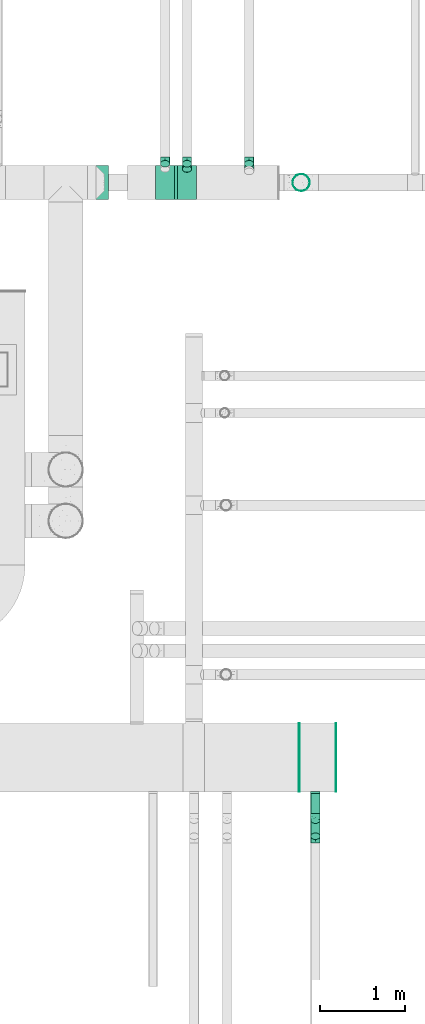
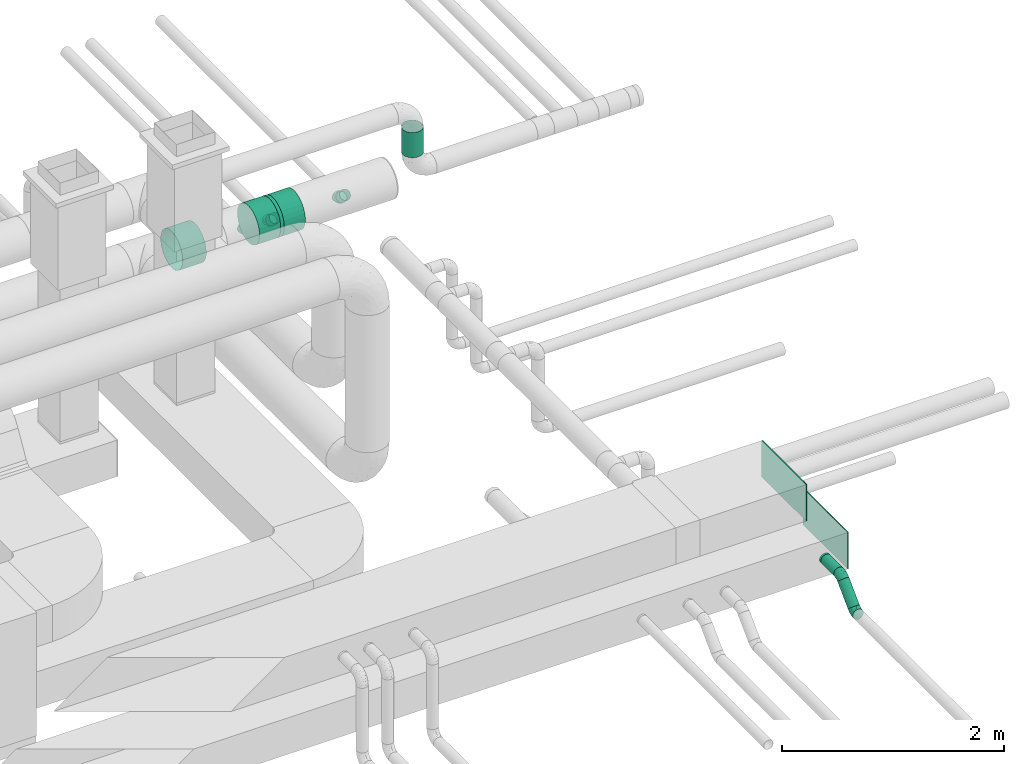
# One storey, part 84 of 91: 10 flow fittings, 7 flow segments.
"""IFC2X3 building model written with IfcOpenShell, lengths in millimetres."""

import ifcopenshell
import ifcopenshell.guid

model = None  # the IFC model being written
_history = None  # IfcOwnerHistory: only IFC2X3 demands one
_inside = {}  # id of a spatial element -> (the spatial element, [elements in it])
_under = {}  # id of a project, library or spatial element -> (it, [spatial elements below it])
_declared = {}  # id of a project -> (the project, [libraries it declares])
_typed = {}  # id of a type object -> (the type object, [elements of that type])
_made_of = {}  # id of a material, layer set ... -> (it, [elements and type objects made of it])


def new_model(schema):
    """Start an empty IFC model of exactly this schema.

    Asked for "IFC4X3", IfcOpenShell would pick the latest addendum, in which some entities
    have other attributes; the version numbers below select the first issue.
    IFC2X3 requires an IfcOwnerHistory on every rooted entity: one is made here for all.
    """
    global model, _history
    if schema == "IFC4X3":
        model = ifcopenshell.file(schema_version=(4, 3, 0, 0))
    else:
        model = ifcopenshell.file(schema=schema)
    _inside.clear()
    _under.clear()
    _declared.clear()
    _typed.clear()
    _made_of.clear()
    _history = None
    if model.schema == "IFC2X3":
        org = make("IfcOrganization", Name="unknown")
        user = make(
            "IfcPersonAndOrganization",
            ThePerson=make("IfcPerson", FamilyName="unknown"),
            TheOrganization=org,
        )
        app = make(
            "IfcApplication",
            ApplicationDeveloper=org,
            Version="unknown",
            ApplicationFullName="unknown",
            ApplicationIdentifier="unknown",
        )
        _history = make(
            "IfcOwnerHistory",
            OwningUser=user,
            OwningApplication=app,
            ChangeAction="ADDED",
            CreationDate=0,
        )
    return model


def make(cls, **values):
    """One entity of the class cls with the attributes given. An attribute that is None is left unset."""
    return model.create_entity(
        cls, **{name: value for name, value in values.items() if value is not None}
    )


def entity(cls, *values):
    """Any entity or typed value of the class cls, its attributes in the order of the schema. None: left unset."""
    e = model.create_entity(cls)
    for i, value in enumerate(values):
        if value is not None:
            e[i] = value
    return e


def rooted(cls, **values):
    """An entity with a GlobalId (a new one), such as an element, a storey or a relation."""
    return make(cls, GlobalId=ifcopenshell.guid.new(), OwnerHistory=_history, **values)


def si_unit(unit_type, name, prefix=None):
    """IfcSIUnit, for example si_unit("LENGTHUNIT", "METRE", prefix="MILLI")."""
    return make("IfcSIUnit", UnitType=unit_type, Prefix=prefix, Name=name)


def converted_unit(unit_type, name, factor, base, dimensions=None, offset=None):
    """IfcConversionBasedUnit, such as the inch: factor (a typed value) times the base unit."""
    return make(
        "IfcConversionBasedUnit"
        if offset is None
        else "IfcConversionBasedUnitWithOffset",
        ConversionOffset=offset,
        Dimensions=None
        if dimensions is None
        else entity("IfcDimensionalExponents", *dimensions),
        UnitType=unit_type,
        Name=name,
        ConversionFactor=make(
            "IfcMeasureWithUnit", ValueComponent=factor, UnitComponent=base
        ),
    )


def derived_unit(unit_type, elements):
    """IfcDerivedUnit: a product of units, each with its exponent."""
    return make(
        "IfcDerivedUnit",
        Elements=[
            make("IfcDerivedUnitElement", Unit=unit, Exponent=power)
            for unit, power in elements
        ],
        UnitType=unit_type,
    )


def assignment(units):
    """IfcUnitAssignment: the units of a project."""
    return None if units is None else make("IfcUnitAssignment", Units=units)


def point(xyz):
    """IfcCartesianPoint."""
    return None if xyz is None else make("IfcCartesianPoint", Coordinates=xyz)


def direction(xyz):
    """IfcDirection."""
    return None if xyz is None else make("IfcDirection", DirectionRatios=xyz)


def frame(location, z_axis=None, x_axis=None):
    """IfcAxis2Placement3D, a coordinate frame: its origin and axes. An axis left out is left unset."""
    return make(
        "IfcAxis2Placement3D",
        Location=point(location),
        Axis=direction(z_axis),
        RefDirection=direction(x_axis),
    )


def frame_2d(location, x_axis=None):
    """IfcAxis2Placement2D, a coordinate frame in the plane: its origin and x axis."""
    return make(
        "IfcAxis2Placement2D", Location=point(location), RefDirection=direction(x_axis)
    )


def origin_with_axes():
    """The frame at (0, 0, 0) with the z axis (0, 0, 1) and the x axis (1, 0, 0) written out."""
    return frame((0.0, 0.0, 0.0), z_axis=(0.0, 0.0, 1.0), x_axis=(1.0, 0.0, 0.0))


def origin_2d_with_axis():
    """The frame at (0, 0) in the plane with the x axis (1, 0) written out."""
    return frame_2d((0.0, 0.0), x_axis=(1.0, 0.0))


def place(relative_to, where):
    """IfcLocalPlacement: puts the frame where relative to a parent placement (None: the world)."""
    return make(
        "IfcLocalPlacement", PlacementRelTo=relative_to, RelativePlacement=where
    )


def context(
    kind, dimensions, precision=None, world=None, true_north=None, identifier=None
):
    """IfcGeometricRepresentationContext, for example the 3D "Model" context."""
    return make(
        "IfcGeometricRepresentationContext",
        ContextIdentifier=identifier,
        ContextType=kind,
        CoordinateSpaceDimension=dimensions,
        Precision=precision,
        WorldCoordinateSystem=world,
        TrueNorth=true_north,
    )


def subcontext(parent, identifier, kind, view, scale=None):
    """IfcGeometricRepresentationSubContext, for example "Body" below "Model"."""
    return make(
        "IfcGeometricRepresentationSubContext",
        ContextIdentifier=identifier,
        ContextType=kind,
        ParentContext=parent,
        TargetScale=scale,
        TargetView=view,
    )


def project(units=None, contexts=None):
    """IfcProject with its units and contexts."""
    return rooted(
        "IfcProject",
        Name="project",
        RepresentationContexts=contexts,
        UnitsInContext=assignment(units),
    )


def spatial(cls, under=None, at=None, **own):
    """A site, building, storey or space (cls), placed at a placement, below another one or the project."""
    s = rooted(cls, ObjectPlacement=at, **own)
    if under is not None:
        _under.setdefault(under.id(), (under, []))[1].append(s)
    return s


def profile(cls, at=None, kind="AREA", **sizes):
    """A parametric profile (cls). Its sizes go by their IFC names, for example OverallWidth=200.0."""
    return make(cls, ProfileType=kind, Position=at, **sizes)


def hollow_circle(**sizes):
    """IfcCircleHollowProfileDef."""
    return profile("IfcCircleHollowProfileDef", **sizes)


def extrude(swept, where, along, depth):
    """IfcExtrudedAreaSolid: the profile swept, set in the frame where, extruded along a direction by depth."""
    return make(
        "IfcExtrudedAreaSolid",
        SweptArea=swept,
        Position=where,
        ExtrudedDirection=direction(along),
        Depth=depth,
    )


def faces_of(points, faces, orient=None, outer=None):
    """IfcFace entities. A face is a list of loops; a loop is a list of indices into points, from 0.

    orient and outer hold one flag for each loop. By default every Orientation is true, the
    first loop of a face is its IfcFaceOuterBound and the others are IfcFaceBound.
    """
    made = []
    for i, loops in enumerate(faces):
        bounds = []
        for j, loop in enumerate(loops):
            is_outer = j == 0 if outer is None else outer[i][j]
            bounds.append(
                make(
                    "IfcFaceOuterBound" if is_outer else "IfcFaceBound",
                    Bound=make("IfcPolyLoop", Polygon=[points[k] for k in loop]),
                    Orientation=True if orient is None else orient[i][j],
                )
            )
        made.append(make("IfcFace", Bounds=bounds))
    return made


def open_shell(faces, orient=None, outer=None):
    """The faces of one IfcOpenShell. surface_model builds it on its shared points."""
    return ("IfcOpenShell", faces, orient, outer)


def surface_model(cls, points, shells):
    """IfcFaceBasedSurfaceModel or IfcShellBasedSurfaceModel (cls): surfaces that need not close."""
    shared = [point(p) for p in points]
    made = [make(c, CfsFaces=faces_of(shared, fs, o, b)) for c, fs, o, b in shells]
    if cls == "IfcFaceBasedSurfaceModel":
        return make(cls, FbsmFaces=made)
    return make(cls, SbsmBoundary=made)


def shape(context_of_items, identifier, shape_type, items):
    """IfcShapeRepresentation: the items that make up one representation, for example the "Body"."""
    return make(
        "IfcShapeRepresentation",
        ContextOfItems=context_of_items,
        RepresentationIdentifier=identifier,
        RepresentationType=shape_type,
        Items=items,
    )


def source(mapping_origin, context_of_items, identifier, shape_type, items):
    """IfcRepresentationMap: a shape defined once, which mapped items show again and again."""
    return make(
        "IfcRepresentationMap",
        MappingOrigin=mapping_origin,
        MappedRepresentation=shape(context_of_items, identifier, shape_type, items),
    )


def transform(
    local_origin,
    x_axis=None,
    y_axis=None,
    z_axis=None,
    scale=None,
    scale2=None,
    scale3=None,
    uniform=True,
):
    """IfcCartesianTransformationOperator3D, or its non-uniform kind. x_axis, y_axis, z_axis: its Axis1, 2, 3."""
    if uniform:
        return make(
            "IfcCartesianTransformationOperator3D",
            Axis1=direction(x_axis),
            Axis2=direction(y_axis),
            LocalOrigin=point(local_origin),
            Scale=scale,
            Axis3=direction(z_axis),
        )
    return make(
        "IfcCartesianTransformationOperator3DnonUniform",
        Axis1=direction(x_axis),
        Axis2=direction(y_axis),
        LocalOrigin=point(local_origin),
        Scale=scale,
        Axis3=direction(z_axis),
        Scale2=scale2,
        Scale3=scale3,
    )


def mapped(mapping_source, mapping_target):
    """IfcMappedItem: shows the shape of a source again, moved by a transform."""
    return make(
        "IfcMappedItem", MappingSource=mapping_source, MappingTarget=mapping_target
    )


def material(Name=None, Category=None):
    """IfcMaterial."""
    return make("IfcMaterial", Name=Name, Category=Category)


def layer(
    of_material, thickness, ventilated=None, Name=None, Category=None, Priority=None
):
    """IfcMaterialLayer: one layer of a wall or slab, of a material (None: an air gap)."""
    return make(
        "IfcMaterialLayer",
        Material=of_material,
        LayerThickness=thickness,
        IsVentilated=ventilated,
        Name=Name,
        Category=Category,
        Priority=Priority,
    )


def layer_set(layers, Name=None):
    """IfcMaterialLayerSet."""
    return make("IfcMaterialLayerSet", MaterialLayers=layers, LayerSetName=Name)


def layer_usage(for_layer_set, set_direction, sense, offset, extent=None):
    """IfcMaterialLayerSetUsage: how a layer set lies in its element."""
    return make(
        "IfcMaterialLayerSetUsage",
        ForLayerSet=for_layer_set,
        LayerSetDirection=set_direction,
        DirectionSense=sense,
        OffsetFromReferenceLine=offset,
        ReferenceExtent=extent,
    )


def made_of(thing, what):
    """Note that an element or type object is made of a material, layer set ...; save() writes the relation."""
    if what is not None:
        _made_of.setdefault(what.id(), (what, []))[1].append(thing)
    return thing


def type_object(cls, material=None, **own):
    """A type object (cls), such as IfcWallType, which elements share."""
    return made_of(rooted(cls, **own), material)


def element(
    cls,
    number,
    at=None,
    inside=None,
    cuts=None,
    type_object=None,
    material=None,
    context=None,
    identifier="Body",
    shape_type=None,
    held_by="IfcProductDefinitionShape",
    body=None,
    shapes=None,
    **own,
):
    """One element of the class cls, such as IfcWall. Its Tag is "e" and its number.

    at: its placement. inside: the storey or other place that contains it. cuts: it is an
    opening in that element (IfcRelVoidsElement). A single representation is given by context,
    identifier, shape_type and body (its items); several are given by shapes. held_by: the class
    of the entity that holds the representations. save() writes the other relations.
    """
    e = rooted(cls, Tag="e%d" % number, ObjectPlacement=at, **own)
    if body is not None:
        shapes = [shape(context, identifier, shape_type, body)]
    if shapes is not None:
        e.Representation = make(held_by, Representations=shapes)
    if inside is not None:
        _inside.setdefault(inside.id(), (inside, []))[1].append(e)
    if cuts is not None:
        rooted(
            "IfcRelVoidsElement", RelatingBuildingElement=cuts, RelatedOpeningElement=e
        )
    if type_object is not None:
        _typed.setdefault(type_object.id(), (type_object, []))[1].append(e)
    return made_of(e, material)


def aggregate(whole, parts):
    """IfcRelAggregates: a whole, such as a stair, and the parts it consists of."""
    return rooted("IfcRelAggregates", RelatingObject=whole, RelatedObjects=parts)


def save(model, path):
    """Write the relations noted so far, then the file.

    IfcRelAggregates (storeys below a building ...), IfcRelContainedInSpatialStructure (elements
    in a storey), IfcRelDefinesByType, IfcRelAssociatesMaterial and IfcRelDeclares: one each for
    every whole, place, type object, material and project.
    """
    for whole, parts in _under.values():
        aggregate(whole, parts)
    for where, things in _inside.values():
        rooted(
            "IfcRelContainedInSpatialStructure",
            RelatedElements=things,
            RelatingStructure=where,
        )
    for kind, things in _typed.values():
        rooted("IfcRelDefinesByType", RelatedObjects=things, RelatingType=kind)
    for what, things in _made_of.values():
        rooted("IfcRelAssociatesMaterial", RelatedObjects=things, RelatingMaterial=what)
    for by, libraries in _declared.values():
        rooted("IfcRelDeclares", RelatingContext=by, RelatedDefinitions=libraries)
    model.write(path)


model = new_model("IFC2X3")

# Units and contexts
model_context = context("Model", 3, precision=1e-05, world=origin_with_axes(), true_north=direction((0.0, 1.0)))
body_context = subcontext(model_context, "Body", "Model", "MODEL_VIEW")
ifc_project = project(units=[si_unit("AREAUNIT", "SQUARE_METRE"), si_unit("VOLUMEUNIT", "CUBIC_METRE", prefix="DECI"), si_unit("TIMEUNIT", "SECOND"), si_unit("THERMODYNAMICTEMPERATUREUNIT", "DEGREE_CELSIUS"), si_unit("PRESSUREUNIT", "PASCAL"), si_unit("MASSUNIT", "GRAM", prefix="KILO"), si_unit("LENGTHUNIT", "METRE", prefix="MILLI"), si_unit("POWERUNIT", "WATT"), si_unit("ELECTRICCURRENTUNIT", "AMPERE"), si_unit("ELECTRICVOLTAGEUNIT", "VOLT"), derived_unit("VOLUMETRICFLOWRATEUNIT", [(si_unit("VOLUMEUNIT", "CUBIC_METRE", prefix="DECI"), 1), (si_unit("TIMEUNIT", "SECOND"), -1)]), derived_unit("LINEARVELOCITYUNIT", [(si_unit("LENGTHUNIT", "METRE"), 1), (si_unit("TIMEUNIT", "SECOND"), -1)]), derived_unit("MASSDENSITYUNIT", [(si_unit("MASSUNIT", "GRAM", prefix="KILO"), 1), (si_unit("VOLUMEUNIT", "CUBIC_METRE"), -1)]), converted_unit("PLANEANGLEUNIT", "DEGREE", entity("IfcRatioMeasure", 0.01745), si_unit("PLANEANGLEUNIT", "RADIAN"), dimensions=[0, 0, 0, 0, 0, 0, 0])], contexts=[model_context])

# Site, building, storey
site_placement = place(None, origin_with_axes())
site = spatial("IfcSite", under=ifc_project, at=site_placement, CompositionType="ELEMENT")
building_placement = place(site_placement, origin_with_axes())
building = spatial("IfcBuilding", under=site, at=building_placement, Name="mc-building", CompositionType="ELEMENT")
storey_placement = place(building_placement, frame((0.0, 0.0, 8700.0), z_axis=(0.0, 0.0, 1.0), x_axis=(1.0, 0.0, 0.0)))
storey = spatial("IfcBuildingStorey", under=building, at=storey_placement, CompositionType="ELEMENT", Elevation=8700.0)

# Flow fittings
duct_fitting_type_1 = type_object("IfcDuctFittingType", PredefinedType="JUNCTION")
shared_shape_1 = source(origin_with_axes(), body_context, "Body", "SurfaceModel", [
    surface_model("IfcShellBasedSurfaceModel", [(0.0, -225.0, -55.0), (14.23505, -225.0, -53.12592), (-14.23505, -225.0, -53.12592), (-53.12592, -225.0, 14.23505), (-27.5, -225.0, -47.63139), (-47.63139, -225.0, -27.5), (-38.89087, -225.0, -38.89087), (55.0, -225.0, 0.0), (53.12592, -225.0, 14.23505), (38.89087, -225.0, -38.89087), (27.5, -225.0, -47.63139), (53.12592, -225.0, -14.23505), (47.63139, -225.0, -27.5), (-53.12592, -225.0, -14.23505), (-47.63139, -225.0, 27.5), (-38.89087, -225.0, 38.89087), (14.23505, -225.0, 53.12592), (-27.5, -225.0, 47.63139), (-14.23505, -225.0, 53.12592), (47.63139, -225.0, 27.5), (38.89087, -225.0, 38.89087), (27.5, -225.0, 47.63139), (0.0, -225.0, 55.0), (-55.0, -225.0, 0.0), (0.0, -192.28884, 55.0), (-12.29394, -192.68144, 53.60839), (-23.92751, -193.77184, 49.52246), (-34.31923, -195.32745, 42.97895), (-42.9874, -197.03532, 34.30865), (-49.52973, -198.56533, 23.91246), (-53.61252, -199.6229, 12.27592), (-55.0, -200.0, 0.0), (-49.52091, -198.56313, -23.93071), (-42.97449, -197.0325, -34.32482), (-53.60826, -199.62175, -12.29447), (-34.30293, -195.32458, -42.99196), (-23.90904, -193.76957, -49.53138), (-12.27509, -192.68024, -53.61271), (0.0, -192.28884, -55.0), (12.29394, -192.68144, -53.60839), (23.92751, -193.77184, -49.52246), (34.31923, -195.32745, -42.97895), (42.9874, -197.03532, -34.30865), (49.52973, -198.56533, -23.91246), (53.61252, -199.6229, -12.27592), (55.0, -200.0, 0.0), (49.52973, -198.56533, 23.91246), (42.9874, -197.03532, 34.30865), (53.61252, -199.6229, 12.27592), (34.31923, -195.32745, 42.97895), (23.92751, -193.77184, 49.52246), (12.29394, -192.68144, 53.60839), (-110.0, 0.0, -200.0), (-110.0, -44.50419, -194.98559), (-110.0, 44.50419, -194.98559), (-110.0, 194.98559, 44.50419), (-110.0, 86.77674, -180.19378), (-110.0, 180.19378, -86.77674), (-110.0, 156.36629, -124.69796), (-110.0, 124.69796, -156.36629), (-110.0, -200.0, 0.0), (-110.0, -194.98559, 44.50419), (-110.0, -124.69796, -156.36629), (-110.0, -86.77674, -180.19378), (-110.0, -156.36629, -124.69796), (-110.0, -180.19378, -86.77674), (-110.0, -194.98559, -44.50419), (-110.0, 194.98559, -44.50419), (-110.0, 180.19378, 86.77674), (-110.0, 156.36629, 124.69796), (-110.0, 86.77674, 180.19378), (-110.0, 124.69796, 156.36629), (-110.0, 44.50419, 194.98559), (-110.0, 0.0, 200.0), (-110.0, -156.36629, 124.69796), (-110.0, -180.19378, 86.77674), (-110.0, -86.77674, 180.19378), (-110.0, -44.50419, 194.98559), (-110.0, -124.69796, 156.36629), (-110.0, 200.0, 0.0), (110.0, 0.0, -200.0), (110.0, 44.50419, -194.98559), (110.0, 86.77674, -180.19378), (110.0, 200.0, 0.0), (110.0, 156.36629, -124.69796), (110.0, 180.19378, -86.77674), (110.0, 124.69796, -156.36629), (110.0, -156.36629, -124.69796), (110.0, -194.98559, 44.50419), (110.0, -86.77674, -180.19378), (110.0, -44.50419, -194.98559), (110.0, -124.69796, -156.36629), (110.0, -180.19378, -86.77674), (110.0, -194.98559, -44.50419), (110.0, -200.0, 0.0), (110.0, 194.98559, -44.50419), (110.0, 194.98559, 44.50419), (110.0, 180.19378, 86.77674), (110.0, 156.36629, 124.69796), (110.0, 124.69796, 156.36629), (110.0, 86.77674, 180.19378), (110.0, 44.50419, 194.98559), (110.0, -156.36629, 124.69796), (110.0, -180.19378, 86.77674), (110.0, -124.69796, 156.36629), (110.0, -86.77674, 180.19378), (110.0, -44.50419, 194.98559), (110.0, 0.0, 200.0), (-110.0, -197.4928, -22.25209), (110.0, -197.4928, -22.25209), (110.0, -197.4928, 22.25209), (-110.0, -197.4928, 22.25209)], [open_shell([[[0, 1, 2]], [[2, 3, 4]], [[5, 6, 3]], [[6, 4, 3]], [[2, 7, 8]], [[9, 7, 10]], [[1, 10, 7]], [[11, 7, 12]], [[9, 12, 7]], [[7, 2, 1]], [[5, 3, 13]], [[2, 14, 3]], [[2, 15, 14]], [[2, 16, 17]], [[17, 15, 2]], [[16, 18, 17]], [[2, 8, 19]], [[2, 19, 20]], [[2, 20, 21]], [[16, 2, 21]], [[16, 22, 18]], [[23, 13, 3]], [[22, 24, 25]], [[18, 25, 26]], [[22, 25, 18]], [[17, 27, 15]], [[17, 18, 26]], [[27, 17, 26]], [[28, 29, 14]], [[30, 31, 23]], [[29, 30, 3]], [[15, 28, 14]], [[3, 14, 29]], [[23, 3, 30]], [[28, 15, 27]], [[32, 33, 5]], [[34, 32, 13]], [[31, 34, 23]], [[23, 34, 13]], [[32, 5, 13]], [[33, 6, 5]], [[4, 35, 36]], [[36, 37, 2]], [[38, 0, 37]], [[4, 6, 35]], [[2, 4, 36]], [[37, 0, 2]], [[35, 6, 33]], [[0, 38, 39]], [[1, 39, 40]], [[0, 39, 1]], [[10, 41, 9]], [[10, 1, 40]], [[41, 10, 40]], [[42, 43, 12]], [[44, 45, 7]], [[43, 44, 11]], [[9, 42, 12]], [[11, 12, 43]], [[7, 11, 44]], [[42, 9, 41]], [[46, 47, 19]], [[48, 46, 8]], [[45, 48, 7]], [[7, 48, 8]], [[46, 19, 8]], [[47, 20, 19]], [[21, 49, 50]], [[50, 51, 16]], [[24, 22, 51]], [[20, 49, 21]], [[16, 21, 50]], [[22, 16, 51]], [[49, 20, 47]], [[52, 53, 54]], [[54, 55, 56]], [[55, 57, 58]], [[58, 59, 55]], [[59, 56, 55]], [[54, 60, 61]], [[62, 60, 63]], [[54, 53, 63]], [[60, 64, 65]], [[65, 66, 60]], [[60, 62, 64]], [[63, 60, 54]], [[55, 67, 57]], [[54, 68, 55]], [[54, 69, 68]], [[70, 71, 69]], [[70, 54, 72]], [[70, 69, 54]], [[72, 54, 73]], [[74, 73, 75]], [[54, 61, 75]], [[76, 77, 73]], [[73, 78, 76]], [[74, 78, 73]], [[54, 75, 73]], [[79, 67, 55]], [[80, 81, 82]], [[83, 80, 82]], [[84, 85, 83]], [[83, 86, 84]], [[83, 82, 86]], [[87, 80, 88]], [[80, 89, 90]], [[80, 91, 89]], [[91, 80, 87]], [[87, 88, 92]], [[93, 92, 88]], [[93, 88, 94]], [[85, 95, 83]], [[83, 96, 97]], [[98, 80, 97]], [[98, 99, 100]], [[80, 100, 101]], [[80, 98, 100]], [[80, 101, 102]], [[102, 103, 80]], [[88, 80, 103]], [[104, 102, 101]], [[104, 101, 105]], [[101, 106, 105]], [[101, 107, 106]], [[83, 97, 80]], [[72, 107, 101]], [[70, 101, 100]], [[71, 100, 99]], [[73, 107, 72]], [[72, 101, 70]], [[100, 71, 70]], [[99, 69, 71]], [[68, 98, 97]], [[55, 97, 96]], [[79, 96, 83]], [[69, 98, 68]], [[68, 97, 55]], [[96, 79, 55]], [[98, 69, 99]], [[83, 95, 79]], [[85, 84, 58]], [[95, 85, 67]], [[67, 79, 95]], [[58, 57, 85]], [[67, 85, 57]], [[84, 59, 58]], [[56, 86, 82]], [[54, 82, 81]], [[52, 81, 80]], [[59, 86, 56]], [[56, 82, 54]], [[81, 52, 54]], [[86, 59, 84]], [[90, 53, 80]], [[89, 63, 90]], [[65, 87, 92]], [[89, 91, 62]], [[87, 64, 91]], [[92, 40, 39]], [[39, 38, 92]], [[53, 90, 63]], [[62, 63, 89]], [[53, 52, 80]], [[38, 37, 65]], [[34, 108, 32]], [[64, 87, 65]], [[37, 36, 65]], [[64, 62, 91]], [[38, 65, 92]], [[42, 109, 43]], [[93, 42, 41]], [[93, 109, 42]], [[41, 40, 93]], [[93, 40, 92]], [[94, 45, 44]], [[43, 109, 44]], [[44, 109, 94]], [[36, 35, 66]], [[33, 32, 108]], [[33, 66, 35]], [[36, 66, 65]], [[34, 60, 108]], [[31, 60, 34]], [[108, 66, 33]], [[45, 94, 48]], [[94, 110, 48]], [[110, 47, 46]], [[47, 110, 88]], [[49, 47, 88]], [[29, 111, 30]], [[60, 31, 30]], [[111, 60, 30]], [[27, 26, 61]], [[61, 111, 28]], [[61, 28, 27]], [[26, 75, 61]], [[49, 88, 50]], [[51, 103, 24]], [[48, 110, 46]], [[51, 50, 103]], [[74, 103, 102]], [[103, 50, 88]], [[105, 106, 77]], [[76, 104, 105]], [[78, 102, 104]], [[73, 106, 107]], [[25, 24, 75]], [[28, 111, 29]], [[75, 24, 103]], [[74, 75, 103]], [[25, 75, 26]], [[102, 78, 74]], [[104, 76, 78]], [[77, 76, 105]], [[106, 73, 77]]])]),
])
for number, where, z_axis, x_axis in (
    (1, (33284.80157, 10080.05037, 668.0), (0.0, 0.707107, 0.707107), (-1.0, 0.0, 0.0)),
    (2, (33028.54629, 10080.05037, 668.0), (0.0, 0.707107, 0.707107), (-1.0, 0.0, 0.0)),
):
    element("IfcFlowFitting", number, at=place(storey_placement, frame(where, z_axis=z_axis, x_axis=x_axis)), inside=storey, type_object=duct_fitting_type_1, context=body_context, shape_type="MappedRepresentation", body=[
        mapped(shared_shape_1, transform((0.0, 0.0, 0.0), scale=1.0)),
    ])

# Flow segment
ifc_material = material(Name="FZ1")
ifc_layer = layer(ifc_material, 0.0)
ifc_layer_set = layer_set([ifc_layer], Name="FZ1")
ifc_layer_usage = layer_usage(ifc_layer_set, "AXIS1", "POSITIVE", 0.0)
duct_segment_type_1 = type_object("IfcDuctSegmentType", PredefinedType="RIGIDSEGMENT")
shared_shape_2 = source(origin_with_axes(), body_context, "Body", "SweptSolid", [
    extrude(hollow_circle(Radius=55.0, WallThickness=2.0, at=origin_2d_with_axis()), frame((0.0, 0.0, 0.0), z_axis=(1.0, 0.0, 0.0), x_axis=(0.0, 1.0, 0.0)), (0.0, 0.0, 1.0), 266.7),
])
flow_segment_1_placement = place(storey_placement, frame((34787.74688, 2620.42338, 635.78175), z_axis=(0.0, -0.707107, 0.707107), x_axis=(0.0, -0.707107, -0.707107)))
element("IfcFlowSegment", 3, at=flow_segment_1_placement, inside=storey, type_object=duct_segment_type_1, material=ifc_layer_usage, context=body_context, shape_type="MappedRepresentation", body=[
    mapped(shared_shape_2, transform((0.0, 0.0, 0.0), scale=1.0)),
])

# Flow fittings
duct_fitting_type_2 = type_object("IfcDuctFittingType", Name="BU", PredefinedType="BEND")
shared_shape_3 = source(origin_with_axes(), body_context, "Body", "SurfaceModel", [
    surface_model("IfcShellBasedSurfaceModel", [(-45.56349, 0.0, -55.0), (-45.56349, -14.23505, -53.12592), (-45.56349, 14.23505, -53.12592), (-45.56349, 53.12592, 14.23505), (-45.56349, 27.5, -47.63139), (-45.56349, 38.89087, -38.89087), (-45.56349, 47.63139, -27.5), (-45.56349, -55.0, 0.0), (-45.56349, -53.12592, 14.23505), (-45.56349, -38.89087, -38.89087), (-45.56349, -27.5, -47.63139), (-45.56349, -53.12592, -14.23505), (-45.56349, -47.63139, -27.5), (-45.56349, 53.12592, -14.23505), (-45.56349, 47.63139, 27.5), (-45.56349, 38.89087, 38.89087), (-45.56349, -14.23505, 53.12592), (-45.56349, 27.5, 47.63139), (-45.56349, 14.23505, 53.12592), (-45.56349, -47.63139, 27.5), (-45.56349, -38.89087, 38.89087), (-45.56349, -27.5, 47.63139), (-45.56349, 0.0, 55.0), (-45.56349, 55.0, 0.0), (22.15256, 42.28395, -53.12592), (-6.67262, 71.10913, 0.0), (32.21826, 32.21826, -55.0), (12.77282, 51.66369, -47.63139), (-1.46223, 65.89874, -27.5), (4.71825, 59.71825, -38.89087), (59.71825, 4.71825, -38.89087), (69.78395, -5.34744, 14.23505), (51.66369, 12.77282, -47.63139), (42.28395, 22.15256, -53.12592), (65.89874, -1.46223, -27.5), (69.78395, -5.34744, -14.23505), (71.10913, -6.67262, 0.0), (-5.34744, 69.78395, -14.23505), (-5.34744, 69.78395, 14.23505), (-1.46223, 65.89874, 27.5), (4.71825, 59.71825, 38.89087), (32.21826, 32.21826, 55.0), (12.77282, 51.66369, 47.63139), (22.15256, 42.28395, 53.12592), (59.71825, 4.71825, 38.89087), (65.89874, -1.46223, 27.5), (42.28395, 22.15256, 53.12592), (51.66369, 12.77282, 47.63139), (-20.16649, 48.68621, 33.48188), (-26.97111, 35.77503, 43.63444), (-7.30443, 43.73336, 43.63444), (-17.0934, 3.74816, 55.0), (-18.00408, 15.44793, 53.78143), (-30.11707, 22.39897, 50.81337), (-7.49776, 55.63651, 33.48188), (-15.97018, 58.74288, 21.04759), (-31.18231, 52.58712, 21.04759), (-18.35174, 61.03934, 10.51509), (-28.67677, 56.60048, 10.47121), (-34.03924, 44.64267, 33.48188), (-11.52288, 27.81868, 50.81338), (1.19951, 23.16465, 53.81115), (-33.77926, 57.34403, 0.0), (5.4586, 37.12132, 50.81809), (-24.5159, 59.18663, 0.0), (-16.66281, 64.4339, 0.0), (9.43651, 14.73721, 55.0), (-6.22531, 44.36822, -43.63444), (5.4586, 37.12132, -50.81809), (-34.03924, 44.64267, -33.48188), (9.43651, 14.73721, -55.0), (-17.0934, 3.74816, -55.0), (1.19951, 23.16465, -53.81115), (-11.52288, 27.81868, -50.81338), (-30.11707, 22.39897, -50.81337), (-25.75914, 36.08917, -43.63444), (-30.24487, 52.83011, -21.04759), (-20.16649, 48.68621, -33.48188), (-7.49776, 55.63651, -33.48188), (-18.00408, 15.44793, -53.78143), (-28.68366, 56.62226, -10.35271), (-14.15883, 63.53074, -10.87592), (-15.13548, 59.23394, -21.04759), (3.19797, -7.72059, -52.16847), (3.1272, -18.04126, -47.9241), (13.63233, -32.91136, -32.06475), (45.23618, -22.99734, -20.4997), (16.67434, -40.25541, -15.9539), (-17.3935, -51.68264, -9.80849), (-2.85835, -49.37776, 0.0), (48.84421, -24.24609, -9.80849), (-16.38424, -42.76862, -30.85433), (-6.97383, -29.41689, -42.70541), (41.82739, -18.65658, -30.85433), (-15.72523, -48.24839, -20.4997), (29.28945, -13.63928, -42.80781), (26.81493, -3.56603, -49.15704), (36.93651, -32.89419, 0.0), (-15.72523, -48.24839, 20.4997), (-17.3935, -51.68264, 9.80849), (-16.38424, -42.76862, 30.85433), (16.67434, -40.25541, 15.9539), (3.19797, -7.72059, 52.16847), (10.54583, -14.96836, 47.9241), (13.63233, -32.91136, 32.06475), (45.23618, -22.99734, 20.4997), (41.82739, -18.65658, 30.85433), (-11.06635, -30.3552, 42.80781), (25.73213, -15.86964, 42.70541), (-16.43945, -21.48258, 49.15704), (48.84421, -24.24609, 9.80849)], [open_shell([[[0, 1, 2]], [[2, 3, 4]], [[5, 3, 6]], [[4, 3, 5]], [[2, 7, 8]], [[9, 7, 10]], [[1, 10, 7]], [[11, 7, 12]], [[9, 12, 7]], [[7, 2, 1]], [[13, 6, 3]], [[14, 3, 2]], [[15, 14, 2]], [[16, 17, 2]], [[2, 17, 15]], [[16, 18, 17]], [[19, 20, 2]], [[19, 2, 8]], [[20, 21, 2]], [[2, 21, 16]], [[16, 22, 18]], [[23, 13, 3]], [[24, 25, 26]], [[27, 25, 24]], [[28, 25, 29]], [[29, 25, 27]], [[30, 26, 31]], [[26, 30, 32]], [[32, 33, 26]], [[34, 31, 35]], [[31, 34, 30]], [[35, 31, 36]], [[37, 25, 28]], [[26, 38, 39]], [[26, 39, 40]], [[41, 40, 42]], [[26, 40, 41]], [[42, 43, 41]], [[26, 44, 45]], [[31, 26, 45]], [[46, 47, 26]], [[47, 44, 26]], [[46, 26, 41]], [[26, 25, 38]], [[48, 49, 50]], [[22, 51, 52]], [[17, 49, 15]], [[53, 17, 18]], [[49, 17, 53]], [[54, 50, 40]], [[48, 55, 56]], [[55, 57, 58]], [[59, 14, 15]], [[60, 53, 52]], [[50, 49, 60]], [[58, 3, 56]], [[52, 51, 61]], [[62, 23, 3]], [[63, 50, 60]], [[50, 42, 40]], [[3, 58, 62]], [[43, 61, 41]], [[62, 58, 64]], [[48, 59, 49]], [[14, 56, 3]], [[40, 39, 54]], [[57, 64, 58]], [[39, 38, 55]], [[63, 60, 61]], [[54, 55, 48]], [[65, 57, 38]], [[56, 14, 59]], [[38, 25, 65]], [[60, 52, 61]], [[49, 59, 15]], [[55, 58, 56]], [[56, 59, 48]], [[55, 54, 39]], [[50, 54, 48]], [[18, 22, 52]], [[49, 53, 60]], [[18, 52, 53]], [[61, 51, 66]], [[41, 61, 66]], [[63, 61, 43]], [[43, 42, 63]], [[50, 63, 42]], [[38, 57, 55]], [[64, 57, 65]], [[67, 27, 68]], [[69, 5, 6]], [[70, 71, 72]], [[73, 74, 75]], [[76, 77, 69]], [[29, 78, 28]], [[2, 79, 0]], [[13, 23, 62]], [[2, 74, 79]], [[5, 75, 4]], [[77, 78, 67]], [[13, 62, 80]], [[64, 80, 62]], [[81, 80, 64]], [[67, 73, 75]], [[82, 77, 76]], [[81, 64, 65]], [[76, 69, 6]], [[82, 76, 80]], [[24, 72, 68]], [[74, 2, 4]], [[27, 67, 29]], [[26, 70, 72]], [[69, 75, 5]], [[82, 28, 78]], [[72, 71, 79]], [[6, 13, 76]], [[77, 67, 75]], [[13, 80, 76]], [[82, 37, 28]], [[81, 25, 37]], [[82, 81, 37]], [[75, 69, 77]], [[67, 78, 29]], [[82, 78, 77]], [[75, 74, 4]], [[79, 74, 73]], [[79, 73, 72]], [[79, 71, 0]], [[68, 72, 73]], [[26, 72, 24]], [[67, 68, 73]], [[27, 24, 68]], [[80, 81, 82]], [[25, 81, 65]], [[1, 83, 84]], [[85, 86, 87]], [[0, 71, 1]], [[88, 87, 89]], [[90, 86, 35]], [[91, 92, 85]], [[11, 88, 7]], [[30, 34, 93]], [[11, 12, 94]], [[92, 91, 9]], [[85, 94, 91]], [[94, 85, 87]], [[95, 93, 85]], [[85, 92, 95]], [[83, 71, 70]], [[12, 9, 91]], [[70, 26, 33]], [[96, 84, 83]], [[1, 71, 83]], [[95, 96, 32]], [[95, 30, 93]], [[95, 32, 30]], [[97, 89, 87]], [[34, 86, 93]], [[36, 97, 90]], [[94, 88, 11]], [[34, 35, 86]], [[90, 87, 86]], [[93, 86, 85]], [[32, 96, 33]], [[84, 10, 1]], [[33, 83, 70]], [[94, 12, 91]], [[10, 92, 9]], [[87, 88, 94]], [[7, 88, 89]], [[36, 90, 35]], [[87, 90, 97]], [[84, 95, 92]], [[33, 96, 83]], [[95, 84, 96]], [[10, 84, 92]], [[8, 98, 19]], [[7, 89, 99]], [[19, 98, 100]], [[101, 98, 99]], [[46, 102, 103]], [[104, 105, 106]], [[100, 98, 104]], [[107, 104, 108]], [[16, 51, 22]], [[51, 16, 102]], [[107, 20, 100]], [[107, 109, 21]], [[21, 20, 107]], [[103, 47, 46]], [[101, 89, 97]], [[105, 110, 31]], [[44, 47, 108]], [[105, 104, 101]], [[107, 100, 104]], [[31, 110, 36]], [[109, 16, 21]], [[108, 106, 44]], [[105, 45, 106]], [[41, 66, 46]], [[102, 66, 51]], [[46, 66, 102]], [[104, 98, 101]], [[99, 98, 8]], [[106, 108, 104]], [[110, 101, 97]], [[45, 44, 106]], [[105, 31, 45]], [[20, 19, 100]], [[109, 103, 102]], [[101, 110, 105]], [[36, 110, 97]], [[7, 99, 8]], [[101, 99, 89]], [[103, 107, 108]], [[16, 109, 102]], [[107, 103, 109]], [[47, 103, 108]]])]),
])
for number, where, z_axis, x_axis, name in (
    (4, (34011.69824, 10333.05037, 415.0), (-1.0, 0.0, 0.0), (0.0, -1.0, 0.0), "BU"),
    (5, (33284.80157, 10333.05037, 415.0), (-1.0, 0.0, 0.0), (0.0, -1.0, 0.0), "BU"),
    (6, (33028.54629, 10333.05037, 415.0), (-1.0, 0.0, 0.0), (0.0, -1.0, 0.0), "BU"),
    (7, (34787.74688, 2652.64164, 668.0), (-1.0, 0.0, 0.0), (0.0, 0.707107, 0.707107), "BU"),
    (8, (34787.74688, 2399.64164, 415.0), (1.0, 0.0, 0.0), (0.0, 1.0, 0.0), "BU"),
):
    element("IfcFlowFitting", number, at=place(storey_placement, frame(where, z_axis=z_axis, x_axis=x_axis)), inside=storey, type_object=duct_fitting_type_2, Name=name, context=body_context, shape_type="MappedRepresentation", body=[
        mapped(shared_shape_3, transform((0.0, 0.0, 0.0), scale=1.0)),
    ])
duct_fitting_type_3 = type_object("IfcDuctFittingType", Name="CC", PredefinedType="CONNECTOR")
shared_shape_4 = source(origin_with_axes(), body_context, "Body", "SurfaceModel", [
    surface_model("IfcShellBasedSurfaceModel", [(-6.096, -55.0, 0.0), (-6.096, 0.0, -55.0), (-6.096, -14.23505, -53.12592), (-6.096, -27.5, -47.63139), (-6.096, -38.89087, -38.89087), (-6.096, -47.63139, -27.5), (-6.096, 38.89087, -38.89087), (-6.096, 53.12592, 14.23505), (-6.096, 27.5, -47.63139), (-6.096, 14.23505, -53.12592), (-6.096, 47.63139, -27.5), (-6.096, 53.12592, -14.23505), (-6.096, 55.0, 0.0), (-6.096, -53.12592, -14.23505), (-6.096, -53.12592, 14.23505), (-6.096, -47.63139, 27.5), (-6.096, -38.89087, 38.89087), (-6.096, 0.0, 55.0), (-6.096, -27.5, 47.63139), (-6.096, -14.23505, 53.12592), (-6.096, 38.89087, 38.89087), (-6.096, 47.63139, 27.5), (-6.096, 14.23505, 53.12592), (-6.096, 27.5, 47.63139), (0.0, -14.23505, 53.12592), (0.0, 0.0, 55.0), (0.0, -27.5, 47.63139), (0.0, -38.89087, 38.89087), (0.0, -53.12592, 14.23505), (0.0, -47.63139, 27.5), (0.0, -55.0, 0.0), (0.0, -53.12592, -14.23505), (0.0, -47.63139, -27.5), (0.0, -38.89087, -38.89087), (0.0, -14.23505, -53.12592), (0.0, -27.5, -47.63139), (0.0, 0.0, -55.0), (0.0, 14.23505, -53.12592), (0.0, 27.5, -47.63139), (0.0, 38.89087, -38.89087), (0.0, 53.12592, -14.23505), (0.0, 47.63139, -27.5), (0.0, 55.0, 0.0), (0.0, 53.12592, 14.23505), (0.0, 47.63139, 27.5), (0.0, 38.89087, 38.89087), (0.0, 14.23505, 53.12592), (0.0, 27.5, 47.63139), (20.0, 0.0, -55.0), (20.0, 14.23505, -53.12592), (20.0, -14.23505, -53.12592), (20.0, -53.12592, 14.23505), (20.0, -27.5, -47.63139), (20.0, -47.63139, -27.5), (20.0, -38.89087, -38.89087), (20.0, 55.0, 0.0), (20.0, 53.12592, 14.23505), (20.0, 38.89087, -38.89087), (20.0, 27.5, -47.63139), (20.0, 53.12592, -14.23505), (20.0, 47.63139, -27.5), (20.0, -53.12592, -14.23505), (20.0, -47.63139, 27.5), (20.0, -38.89087, 38.89087), (20.0, 14.23505, 53.12592), (20.0, -27.5, 47.63139), (20.0, -14.23505, 53.12592), (20.0, 47.63139, 27.5), (20.0, 38.89087, 38.89087), (20.0, 27.5, 47.63139), (20.0, 0.0, 55.0), (20.0, -55.0, 0.0)], [open_shell([[[0, 1, 2]], [[3, 0, 2]], [[0, 4, 5]], [[4, 0, 3]], [[6, 1, 7]], [[1, 6, 8]], [[8, 9, 1]], [[6, 7, 10]], [[10, 7, 11]], [[12, 11, 7]], [[13, 0, 5]], [[14, 15, 1]], [[1, 15, 16]], [[17, 16, 18]], [[17, 1, 16]], [[19, 17, 18]], [[20, 21, 1]], [[7, 1, 21]], [[22, 23, 1]], [[23, 20, 1]], [[22, 1, 17]], [[0, 14, 1]], [[24, 25, 17]], [[26, 24, 19]], [[19, 24, 17]], [[16, 27, 18]], [[26, 19, 18]], [[26, 18, 27]], [[28, 29, 15]], [[30, 28, 14]], [[15, 29, 16]], [[28, 15, 14]], [[30, 14, 0]], [[27, 16, 29]], [[31, 30, 0]], [[32, 31, 13]], [[13, 31, 0]], [[4, 33, 5]], [[32, 13, 5]], [[32, 5, 33]], [[34, 35, 3]], [[36, 34, 2]], [[3, 35, 4]], [[34, 3, 2]], [[36, 2, 1]], [[33, 4, 35]], [[37, 36, 1]], [[38, 37, 9]], [[9, 37, 1]], [[6, 39, 8]], [[38, 9, 8]], [[38, 8, 39]], [[40, 41, 10]], [[42, 40, 11]], [[10, 41, 6]], [[40, 10, 11]], [[42, 11, 12]], [[39, 6, 41]], [[43, 42, 12]], [[44, 43, 7]], [[7, 43, 12]], [[20, 45, 21]], [[44, 7, 21]], [[44, 21, 45]], [[46, 47, 23]], [[25, 46, 22]], [[23, 47, 20]], [[46, 23, 22]], [[25, 22, 17]], [[45, 20, 47]], [[48, 49, 50]], [[50, 51, 52]], [[53, 54, 51]], [[52, 51, 54]], [[50, 55, 56]], [[57, 55, 58]], [[49, 58, 55]], [[59, 55, 60]], [[57, 60, 55]], [[55, 50, 49]], [[53, 51, 61]], [[50, 62, 51]], [[63, 62, 50]], [[64, 65, 50]], [[65, 63, 50]], [[64, 66, 65]], [[50, 67, 68]], [[67, 50, 56]], [[68, 69, 50]], [[50, 69, 64]], [[64, 70, 66]], [[71, 61, 51]], [[66, 70, 25]], [[65, 66, 24]], [[24, 66, 25]], [[27, 63, 26]], [[65, 24, 26]], [[65, 26, 63]], [[51, 62, 29]], [[71, 51, 28]], [[29, 62, 27]], [[51, 29, 28]], [[71, 28, 30]], [[63, 27, 62]], [[61, 71, 30]], [[53, 61, 31]], [[31, 61, 30]], [[33, 54, 32]], [[53, 31, 32]], [[53, 32, 54]], [[50, 52, 35]], [[48, 50, 34]], [[35, 52, 33]], [[50, 35, 34]], [[48, 34, 36]], [[54, 33, 52]], [[49, 48, 36]], [[58, 49, 37]], [[37, 49, 36]], [[39, 57, 38]], [[58, 37, 38]], [[58, 38, 57]], [[59, 60, 41]], [[55, 59, 40]], [[41, 60, 39]], [[59, 41, 40]], [[55, 40, 42]], [[57, 39, 60]], [[56, 55, 42]], [[67, 56, 43]], [[43, 56, 42]], [[45, 68, 44]], [[67, 43, 44]], [[67, 44, 68]], [[64, 69, 47]], [[70, 64, 46]], [[47, 69, 45]], [[64, 47, 46]], [[70, 46, 25]], [[68, 45, 69]], [[50, 63, 62]], [[50, 64, 65]], [[50, 56, 67]], [[50, 68, 69]], [[64, 50, 69]]])]),
])
flow_fitting_placement = place(storey_placement, frame((34787.74688, 2951.20513, 668.0), z_axis=(0.0, 0.0, -1.0), x_axis=(0.0, -1.0, 0.0)))
element("IfcFlowFitting", 9, at=flow_fitting_placement, inside=storey, type_object=duct_fitting_type_3, Name="CC", context=body_context, shape_type="MappedRepresentation", body=[
    mapped(shared_shape_4, transform((0.0, 0.0, 0.0), scale=1.0)),
])
duct_fitting_type_4 = type_object("IfcDuctFittingType", Name="R", PredefinedType="OBSTRUCTION")
shared_shape_5 = source(origin_with_axes(), body_context, "Body", "SurfaceModel", [
    surface_model("IfcShellBasedSurfaceModel", [(0.0, 400.0, 200.0), (0.0, 400.0, -200.0), (0.0, -400.0, -200.0), (0.0, -400.0, 200.0), (10.0, -400.0, -200.0), (10.0, 400.0, -200.0), (10.0, -400.0, 200.0), (10.0, 400.0, 200.0)], [open_shell([[[0, 1, 2]], [[2, 3, 0]], [[4, 5, 6]], [[7, 6, 5]], [[1, 0, 7]], [[7, 5, 1]], [[2, 1, 5]], [[5, 4, 2]], [[3, 2, 4]], [[4, 6, 3]], [[0, 3, 7]], [[6, 7, 3]]])]),
])
for number, where, z_axis, x_axis, name in (
    (10, (35023.78802, 3351.20513, 668.0), (0.0, 0.0, 1.0), (1.0, 0.0, 0.0), "R"),
    (11, (34593.21363, 3351.20513, 1344.0), (0.0, 0.0, 1.0), (1.0, 0.0, 0.0), "R"),
):
    element("IfcFlowFitting", number, at=place(storey_placement, frame(where, z_axis=z_axis, x_axis=x_axis)), inside=storey, type_object=duct_fitting_type_4, Name=name, context=body_context, shape_type="MappedRepresentation", body=[
        mapped(shared_shape_5, transform((0.0, 0.0, 0.0), scale=1.0)),
    ])

# Flow segments
shared_shape_6 = source(origin_with_axes(), body_context, "Body", "SweptSolid", [
    extrude(hollow_circle(Radius=55.0, WallThickness=2.0, at=origin_2d_with_axis()), frame((0.0, 0.0, 0.0), z_axis=(1.0, 0.0, 0.0), x_axis=(0.0, 1.0, 0.0)), (0.0, 0.0, 1.0), 233.0),
])
flow_segment_2_placement = place(storey_placement, frame((34787.74688, 2931.20513, 668.0), z_axis=(0.0, 0.0, 1.0), x_axis=(0.0, -1.0, 0.0)))
element("IfcFlowSegment", 12, at=flow_segment_2_placement, inside=storey, type_object=duct_segment_type_1, material=ifc_layer_usage, context=body_context, shape_type="MappedRepresentation", body=[
    mapped(shared_shape_6, transform((0.0, 0.0, 0.0), scale=1.0)),
])
shared_shape_7 = source(origin_with_axes(), body_context, "Body", "SweptSolid", [
    extrude(hollow_circle(Radius=55.0, WallThickness=2.0, at=origin_2d_with_axis()), frame((0.0, 0.0, 0.0), z_axis=(1.0, 0.0, 0.0), x_axis=(0.0, 1.0, 0.0)), (0.0, 0.0, 1.0), 87.2),
])
flow_segment_3_placement = place(storey_placement, frame((33284.80157, 10239.14939, 508.90097), z_axis=(0.0, -0.707107, -0.707107), x_axis=(0.0, 0.707107, -0.707107)))
element("IfcFlowSegment", 13, at=flow_segment_3_placement, inside=storey, type_object=duct_segment_type_1, material=ifc_layer_usage, context=body_context, shape_type="MappedRepresentation", body=[
    mapped(shared_shape_7, transform((0.0, 0.0, 0.0), scale=1.0)),
])
shared_shape_8 = source(origin_with_axes(), body_context, "Body", "SweptSolid", [
    extrude(hollow_circle(Radius=55.0, WallThickness=2.0, at=origin_2d_with_axis()), frame((0.0, 0.0, 0.0), z_axis=(1.0, 0.0, 0.0), x_axis=(0.0, 1.0, 0.0)), (0.0, 0.0, 1.0), 92.2),
])
flow_segment_4_placement = place(storey_placement, frame((34011.69824, 10235.61386, 512.43651), z_axis=(0.0, -0.707107, -0.707107), x_axis=(0.0, 0.707107, -0.707107)))
element("IfcFlowSegment", 14, at=flow_segment_4_placement, inside=storey, type_object=duct_segment_type_1, material=ifc_layer_usage, context=body_context, shape_type="MappedRepresentation", body=[
    mapped(shared_shape_8, transform((0.0, 0.0, 0.0), scale=1.0)),
])
duct_segment_type_2 = type_object("IfcDuctSegmentType", Name="Safe", PredefinedType="RIGIDSEGMENT")
shared_shape_9 = source(origin_with_axes(), body_context, "Body", "SweptSolid", [
    extrude(hollow_circle(Radius=200.0, WallThickness=2.0, at=origin_2d_with_axis()), frame((0.0, 0.0, 0.0), z_axis=(1.0, 0.0, 0.0), x_axis=(0.0, 1.0, 0.0)), (0.0, 0.0, 1.0), 36.3),
])
flow_segment_5_placement = place(storey_placement, frame((33138.54629, 10080.05037, 668.0), z_axis=(0.0, 0.0, 1.0), x_axis=(1.0, 0.0, 0.0)))
element("IfcFlowSegment", 15, at=flow_segment_5_placement, inside=storey, type_object=duct_segment_type_2, material=ifc_layer_usage, Name="Safe", context=body_context, shape_type="MappedRepresentation", body=[
    mapped(shared_shape_9, transform((0.0, 0.0, 0.0), scale=1.0)),
])
shared_shape_10 = source(origin_with_axes(), body_context, "Body", "SweptSolid", [
    extrude(hollow_circle(Radius=200.0, WallThickness=2.0, at=origin_2d_with_axis()), frame((0.0, 0.0, 0.0), z_axis=(1.0, 0.0, 0.0), x_axis=(0.0, 1.0, 0.0)), (0.0, 0.0, 1.0), 245.0),
])
flow_segment_6_placement = place(storey_placement, frame((32366.59509, 10080.05037, 668.0), z_axis=(0.0, 0.0, 1.0), x_axis=(-1.0, 0.0, 0.0)))
element("IfcFlowSegment", 16, at=flow_segment_6_placement, inside=storey, type_object=duct_segment_type_2, material=ifc_layer_usage, Name="Safe", context=body_context, shape_type="MappedRepresentation", body=[
    mapped(shared_shape_10, transform((0.0, 0.0, 0.0), scale=1.0)),
])
shared_shape_11 = source(origin_with_axes(), body_context, "Body", "SweptSolid", [
    extrude(hollow_circle(Radius=100.0, WallThickness=2.0, at=origin_2d_with_axis()), frame((0.0, 0.0, 0.0), z_axis=(1.0, 0.0, 0.0), x_axis=(0.0, 1.0, 0.0)), (0.0, 0.0, 1.0), 276.0),
])
flow_segment_7_placement = place(storey_placement, frame((34621.56389, 10080.96985, 1144.0), z_axis=(-1.0, 0.0, 0.0), x_axis=(0.0, 0.0, -1.0)))
element("IfcFlowSegment", 17, at=flow_segment_7_placement, inside=storey, type_object=duct_segment_type_2, material=ifc_layer_usage, Name="Safe", context=body_context, shape_type="MappedRepresentation", body=[
    mapped(shared_shape_11, transform((0.0, 0.0, 0.0), scale=1.0)),
])

save(model, "model.ifc")
